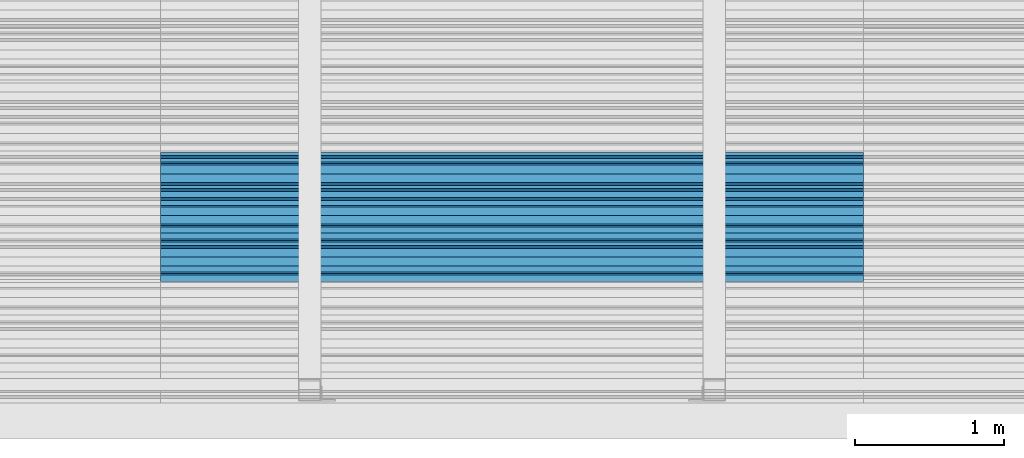
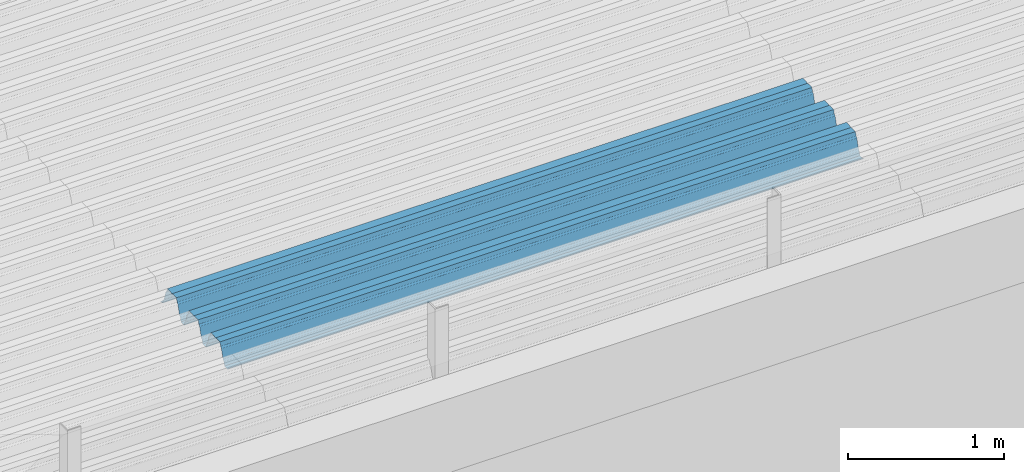
# One storey, part 30 of 153: 1 beam, 1 element without a shape of its own.
"""IFC2X3 building model written with IfcOpenShell, lengths in millimetres."""

import ifcopenshell
import ifcopenshell.guid

model = None  # the IFC model being written
_history = None  # IfcOwnerHistory: only IFC2X3 demands one
_inside = {}  # id of a spatial element -> (the spatial element, [elements in it])
_under = {}  # id of a project, library or spatial element -> (it, [spatial elements below it])
_declared = {}  # id of a project -> (the project, [libraries it declares])
_typed = {}  # id of a type object -> (the type object, [elements of that type])
_made_of = {}  # id of a material, layer set ... -> (it, [elements and type objects made of it])


def new_model(schema):
    """Start an empty IFC model of exactly this schema.

    Asked for "IFC4X3", IfcOpenShell would pick the latest addendum, in which some entities
    have other attributes; the version numbers below select the first issue.
    IFC2X3 requires an IfcOwnerHistory on every rooted entity: one is made here for all.
    """
    global model, _history
    if schema == "IFC4X3":
        model = ifcopenshell.file(schema_version=(4, 3, 0, 0))
    else:
        model = ifcopenshell.file(schema=schema)
    _inside.clear()
    _under.clear()
    _declared.clear()
    _typed.clear()
    _made_of.clear()
    _history = None
    if model.schema == "IFC2X3":
        org = make("IfcOrganization", Name="unknown")
        user = make(
            "IfcPersonAndOrganization",
            ThePerson=make("IfcPerson", FamilyName="unknown"),
            TheOrganization=org,
        )
        app = make(
            "IfcApplication",
            ApplicationDeveloper=org,
            Version="unknown",
            ApplicationFullName="unknown",
            ApplicationIdentifier="unknown",
        )
        _history = make(
            "IfcOwnerHistory",
            OwningUser=user,
            OwningApplication=app,
            ChangeAction="ADDED",
            CreationDate=0,
        )
    return model


def make(cls, **values):
    """One entity of the class cls with the attributes given. An attribute that is None is left unset."""
    return model.create_entity(
        cls, **{name: value for name, value in values.items() if value is not None}
    )


def rooted(cls, **values):
    """An entity with a GlobalId (a new one), such as an element, a storey or a relation."""
    return make(cls, GlobalId=ifcopenshell.guid.new(), OwnerHistory=_history, **values)


def si_unit(unit_type, name, prefix=None):
    """IfcSIUnit, for example si_unit("LENGTHUNIT", "METRE", prefix="MILLI")."""
    return make("IfcSIUnit", UnitType=unit_type, Prefix=prefix, Name=name)


def assignment(units):
    """IfcUnitAssignment: the units of a project."""
    return None if units is None else make("IfcUnitAssignment", Units=units)


def point(xyz):
    """IfcCartesianPoint."""
    return None if xyz is None else make("IfcCartesianPoint", Coordinates=xyz)


def direction(xyz):
    """IfcDirection."""
    return None if xyz is None else make("IfcDirection", DirectionRatios=xyz)


def frame(location, z_axis=None, x_axis=None):
    """IfcAxis2Placement3D, a coordinate frame: its origin and axes. An axis left out is left unset."""
    return make(
        "IfcAxis2Placement3D",
        Location=point(location),
        Axis=direction(z_axis),
        RefDirection=direction(x_axis),
    )


def origin_with_axes():
    """The frame at (0, 0, 0) with the z axis (0, 0, 1) and the x axis (1, 0, 0) written out."""
    return frame((0.0, 0.0, 0.0), z_axis=(0.0, 0.0, 1.0), x_axis=(1.0, 0.0, 0.0))


def place(relative_to, where):
    """IfcLocalPlacement: puts the frame where relative to a parent placement (None: the world)."""
    return make(
        "IfcLocalPlacement", PlacementRelTo=relative_to, RelativePlacement=where
    )


def context(
    kind, dimensions, precision=None, world=None, true_north=None, identifier=None
):
    """IfcGeometricRepresentationContext, for example the 3D "Model" context."""
    return make(
        "IfcGeometricRepresentationContext",
        ContextIdentifier=identifier,
        ContextType=kind,
        CoordinateSpaceDimension=dimensions,
        Precision=precision,
        WorldCoordinateSystem=world,
        TrueNorth=true_north,
    )


def subcontext(parent, identifier, kind, view, scale=None):
    """IfcGeometricRepresentationSubContext, for example "Body" below "Model"."""
    return make(
        "IfcGeometricRepresentationSubContext",
        ContextIdentifier=identifier,
        ContextType=kind,
        ParentContext=parent,
        TargetScale=scale,
        TargetView=view,
    )


def project(units=None, contexts=None):
    """IfcProject with its units and contexts."""
    return rooted(
        "IfcProject",
        Name="project",
        RepresentationContexts=contexts,
        UnitsInContext=assignment(units),
    )


def spatial(cls, under=None, at=None, **own):
    """A site, building, storey or space (cls), placed at a placement, below another one or the project."""
    s = rooted(cls, ObjectPlacement=at, **own)
    if under is not None:
        _under.setdefault(under.id(), (under, []))[1].append(s)
    return s


def faces_of(points, faces, orient=None, outer=None):
    """IfcFace entities. A face is a list of loops; a loop is a list of indices into points, from 0.

    orient and outer hold one flag for each loop. By default every Orientation is true, the
    first loop of a face is its IfcFaceOuterBound and the others are IfcFaceBound.
    """
    made = []
    for i, loops in enumerate(faces):
        bounds = []
        for j, loop in enumerate(loops):
            is_outer = j == 0 if outer is None else outer[i][j]
            bounds.append(
                make(
                    "IfcFaceOuterBound" if is_outer else "IfcFaceBound",
                    Bound=make("IfcPolyLoop", Polygon=[points[k] for k in loop]),
                    Orientation=True if orient is None else orient[i][j],
                )
            )
        made.append(make("IfcFace", Bounds=bounds))
    return made


def faceted_brep(points, faces, orient=None, outer=None, voids=None):
    """IfcFacetedBrep: a solid bounded by flat faces; with voids (closed shells), ...WithVoids."""
    shared = [point(p) for p in points]
    hull = make("IfcClosedShell", CfsFaces=faces_of(shared, faces, orient, outer))
    if voids is None:
        return make("IfcFacetedBrep", Outer=hull)
    return make(
        "IfcFacetedBrepWithVoids",
        Outer=hull,
        Voids=[
            make(cls, CfsFaces=faces_of(shared, fs, o, b)) for cls, fs, o, b in voids
        ],
    )


def shape(context_of_items, identifier, shape_type, items):
    """IfcShapeRepresentation: the items that make up one representation, for example the "Body"."""
    return make(
        "IfcShapeRepresentation",
        ContextOfItems=context_of_items,
        RepresentationIdentifier=identifier,
        RepresentationType=shape_type,
        Items=items,
    )


def material(Name=None, Category=None):
    """IfcMaterial."""
    return make("IfcMaterial", Name=Name, Category=Category)


def made_of(thing, what):
    """Note that an element or type object is made of a material, layer set ...; save() writes the relation."""
    if what is not None:
        _made_of.setdefault(what.id(), (what, []))[1].append(thing)
    return thing


def type_object(cls, material=None, **own):
    """A type object (cls), such as IfcWallType, which elements share."""
    return made_of(rooted(cls, **own), material)


def element(
    cls,
    number,
    at=None,
    inside=None,
    cuts=None,
    type_object=None,
    material=None,
    context=None,
    identifier="Body",
    shape_type=None,
    held_by="IfcProductDefinitionShape",
    body=None,
    shapes=None,
    **own,
):
    """One element of the class cls, such as IfcWall. Its Tag is "e" and its number.

    at: its placement. inside: the storey or other place that contains it. cuts: it is an
    opening in that element (IfcRelVoidsElement). A single representation is given by context,
    identifier, shape_type and body (its items); several are given by shapes. held_by: the class
    of the entity that holds the representations. save() writes the other relations.
    """
    e = rooted(cls, Tag="e%d" % number, ObjectPlacement=at, **own)
    if body is not None:
        shapes = [shape(context, identifier, shape_type, body)]
    if shapes is not None:
        e.Representation = make(held_by, Representations=shapes)
    if inside is not None:
        _inside.setdefault(inside.id(), (inside, []))[1].append(e)
    if cuts is not None:
        rooted(
            "IfcRelVoidsElement", RelatingBuildingElement=cuts, RelatedOpeningElement=e
        )
    if type_object is not None:
        _typed.setdefault(type_object.id(), (type_object, []))[1].append(e)
    return made_of(e, material)


def aggregate(whole, parts):
    """IfcRelAggregates: a whole, such as a stair, and the parts it consists of."""
    return rooted("IfcRelAggregates", RelatingObject=whole, RelatedObjects=parts)


def save(model, path):
    """Write the relations noted so far, then the file.

    IfcRelAggregates (storeys below a building ...), IfcRelContainedInSpatialStructure (elements
    in a storey), IfcRelDefinesByType, IfcRelAssociatesMaterial and IfcRelDeclares: one each for
    every whole, place, type object, material and project.
    """
    for whole, parts in _under.values():
        aggregate(whole, parts)
    for where, things in _inside.values():
        rooted(
            "IfcRelContainedInSpatialStructure",
            RelatedElements=things,
            RelatingStructure=where,
        )
    for kind, things in _typed.values():
        rooted("IfcRelDefinesByType", RelatedObjects=things, RelatingType=kind)
    for what, things in _made_of.values():
        rooted("IfcRelAssociatesMaterial", RelatedObjects=things, RelatingMaterial=what)
    for by, libraries in _declared.values():
        rooted("IfcRelDeclares", RelatingContext=by, RelatedDefinitions=libraries)
    model.write(path)


model = new_model("IFC2X3")

# Units and contexts
model_context = context("Model", 3, precision=1e-05, world=origin_with_axes())
body_context = subcontext(model_context, "Body", "Model", "MODEL_VIEW")
ifc_project = project(units=[si_unit("LENGTHUNIT", "METRE", prefix="MILLI"), si_unit("AREAUNIT", "SQUARE_METRE"), si_unit("VOLUMEUNIT", "CUBIC_METRE"), si_unit("MASSUNIT", "GRAM", prefix="KILO"), si_unit("TIMEUNIT", "SECOND"), si_unit("PLANEANGLEUNIT", "RADIAN"), si_unit("SOLIDANGLEUNIT", "STERADIAN"), si_unit("THERMODYNAMICTEMPERATUREUNIT", "DEGREE_CELSIUS"), si_unit("LUMINOUSINTENSITYUNIT", "LUMEN")], contexts=[model_context])

# Site, building, storey
site_placement = place(None, origin_with_axes())
site = spatial("IfcSite", under=ifc_project, at=site_placement, CompositionType="ELEMENT")
building_placement = place(site_placement, origin_with_axes())
building = spatial("IfcBuilding", under=site, at=building_placement, CompositionType="ELEMENT")
storey_placement = place(building_placement, origin_with_axes())
storey = spatial("IfcBuildingStorey", under=building, at=storey_placement, Name="8", CompositionType="ELEMENT", Elevation=0.0)

# Assembly, beam
assembly_placement = place(storey_placement, origin_with_axes())
assembly = element("IfcElementAssembly", 1, at=assembly_placement, inside=storey, Name="Steel Assembly", AssemblyPlace="NOTDEFINED", PredefinedType="RIGID_FRAME")
ifc_material = material(Name="STEEL/S355J2")
beam_type = type_object("IfcBeamType", Name="W", PredefinedType="NOTDEFINED")
beam_placement = place(assembly_placement, frame((17251.9999999917, 16215.1442180518, 105760.274680724), z_axis=(0.0, -0.0124990270013869, 0.999921884110963), x_axis=(-1.0, 3.00000001838171e-08, 0.0)))
beam = element("IfcBeam", 2, at=beam_placement, type_object=beam_type, material=ifc_material, ObjectType="W", context=body_context, shape_type="Brep", body=[
    faceted_brep([(0.0, -412.839996337891, -77.0100021362159), (0.0, -409.160003662109, -77.0100021362014), (4717.0, -409.160003662109, -77.0100021362159), (4717.0, -412.839996337891, -77.0100021362159), (0.0, -408.070007324222, -73.4800033569045), (4717.0, -408.070007324222, -73.480003356919), (0.0, -400.339996337894, -48.0600013732619), (4717.0, -400.339996337894, -48.0600013732765), (0.0, -399.459991455082, -46.5600013732619), (4717.0, -399.459991455078, -46.5600013732765), (0.0, -390.329986572269, -36.5499992370314), (4717.0, -390.329986572266, -36.549999237046), (0.0, -389.19000244141, -34.6300010680861), (4717.0, -389.190002441403, -34.6300010681007), (0.0, -367.820007324222, 35.3400001526024), (4717.0, -367.820007324219, 35.3400001525879), (0.0, -366.989990234379, 36.8499984741502), (4717.0, -366.989990234375, 36.8499984741356), (0.0, -357.809997558597, 46.8600006103807), (4717.0, -357.809997558594, 46.8600006103661), (0.0, -356.720001220707, 48.7700004577782), (4717.0, -356.720001220703, 48.7700004577782), (0.0, -349.309997558594, 73.1500015258935), (4717.0, -349.309997558594, 73.1500015258935), (0.0, -347.850006103516, 75.2300033569481), (4717.0, -347.850006103516, 75.2300033569481), (0.0, -345.470001220707, 76.010002136245), (4717.0, -345.470001220703, 76.0100021362305), (0.0, -305.480010986332, 76.010002136245), (4717.0, -305.480010986324, 76.0100021362305), (0.0, -304.279998779301, 75.8000030517578), (4717.0, -304.279998779301, 75.8000030517724), (0.0, -291.679992675785, 71.6999969482567), (4717.0, -291.679992675785, 71.6999969482567), (0.0, -290.179992675789, 71.2300033569481), (4717.0, -290.179992675781, 71.2300033569481), (0.0, -288.720001220707, 71.6999969482567), (4717.0, -288.720001220703, 71.6999969482422), (0.0, -276.119995117191, 75.8000030517869), (4717.0, -276.119995117188, 75.8000030517724), (0.0, -274.929992675785, 76.010002136245), (4717.0, -274.929992675785, 76.010002136245), (0.0, -234.94000244141, 76.010002136245), (4717.0, -234.94000244141, 76.010002136245), (0.0, -232.550003051758, 75.2300033569627), (4717.0, -232.550003051758, 75.2300033569481), (0.0, -231.100006103519, 73.1500015258935), (4717.0, -231.100006103516, 73.1500015258789), (0.0, -223.679992675785, 48.7700004577782), (4717.0, -223.679992675781, 48.7700004577782), (0.0, -222.589996337894, 46.8600006103661), (4717.0, -222.589996337891, 46.8600006103516), (0.0, -213.410003662113, 36.8499984741502), (4717.0, -213.410003662109, 36.8499984741356), (0.0, -212.529998779301, 35.3400001526024), (4717.0, -212.529998779297, 35.3400001526024), (0.0, -191.160003662109, -34.6300010681007), (4717.0, -191.160003662109, -34.6300010681007), (0.0, -190.070007324222, -36.5499992370605), (4717.0, -190.070007324215, -36.549999237046), (0.0, -180.940002441406, -46.560001373291), (4717.0, -180.940002441406, -46.5600013732765), (0.0, -180.059997558597, -48.0600013732619), (4717.0, -180.059997558594, -48.0600013732765), (0.0, -172.330001831055, -73.480003356919), (4717.0, -172.330001831055, -73.480003356919), (0.0, -171.240005493168, -77.0100021362159), (4717.0, -171.240005493164, -77.0100021362159), (0.0, -129.330001831062, -77.0100021362014), (4717.0, -129.330001831055, -77.0100021362159), (0.0, -128.300003051761, -73.480003356919), (4717.0, -128.300003051758, -73.4800033569336), (0.0, -120.51999664307, -48.0600013732765), (4717.0, -120.519996643063, -48.0600013732765), (0.0, -119.629997253418, -46.5600013732765), (4717.0, -119.629997253418, -46.5600013732765), (0.0, -110.500000000004, -36.5499992370314), (4717.0, -110.5, -36.549999237046), (0.0, -109.419998168949, -34.6300010680861), (4717.0, -109.419998168945, -34.6300010681007), (0.0, -88.0500030517615, 35.3400001526024), (4717.0, -88.0500030517578, 35.3400001526024), (0.0, -87.160003662113, 36.8499984741356), (4717.0, -87.160003662113, 36.8499984741356), (0.0, -78.0400009155273, 46.8600006103807), (4717.0, -78.0400009155273, 46.8600006103661), (0.0, -76.8899993896557, 48.7700004577782), (4717.0, -76.8899993896521, 48.7700004577782), (0.0, -69.4800033569336, 73.1500015258935), (4717.0, -69.4800033569336, 73.1500015258935), (0.0, -68.0299987793042, 75.2300033569336), (4717.0, -68.0299987792969, 75.2300033569481), (0.0, -65.6399993896521, 76.010002136245), (4717.0, -65.6399993896484, 76.010002136245), (0.0, -25.6499996185375, 76.0100021362596), (4717.0, -25.6499996185303, 76.010002136245), (0.0, -24.5100002288891, 75.8000030517724), (4717.0, -24.5100002288818, 75.8000030517724), (0.0, -11.8500003814697, 71.6999969482567), (4717.0, -11.8500003814661, 71.6999969482567), (0.0, -10.3999996185339, 71.2300033569481), (4717.0, -10.3999996185303, 71.2300033569336), (0.0, -8.89999961853391, 71.6999969482567), (4717.0, -8.89999961853391, 71.6999969482567), (0.0, 3.71000003814333, 75.8000030517724), (4717.0, 3.71000003814697, 75.8000030517869), (0.0, 4.90000009536379, 76.0100021362596), (4717.0, 4.90000009536379, 76.010002136245), (0.0, 44.8899993896484, 76.010002136245), (4717.0, 44.8899993896484, 76.010002136245), (0.0, 47.2799987792932, 75.2300033569481), (4717.0, 47.2799987792969, 75.2300033569481), (0.0, 48.6800003051721, 73.1500015258935), (4717.0, 48.6800003051758, 73.1500015258789), (0.0, 56.1500015258753, 48.7700004577782), (4717.0, 56.1500015258789, 48.7700004577782), (0.0, 57.2400016784632, 46.8600006103807), (4717.0, 57.2400016784632, 46.8600006103661), (0.0, 66.3700027465784, 36.8499984741211), (4717.0, 66.3700027465857, 36.8499984741356), (0.0, 67.2499999999964, 35.3400001526024), (4717.0, 67.2500000000036, 35.3400001526024), (0.0, 88.6200027465748, -34.6300010681007), (4717.0, 88.620002746582, -34.6300010681152), (0.0, 89.709999084469, -36.549999237046), (4717.0, 89.7099990844727, -36.5499992370605), (0.0, 98.8899993896412, -46.5600013732765), (4717.0, 98.8899993896484, -46.5600013732765), (0.0, 99.7699966430628, -48.0600013732765), (4717.0, 99.7699966430664, -48.060001373291), (0.0, 107.499999999996, -73.4800033569336), (4717.0, 107.5, -73.480003356919), (0.0, 108.589996337887, -77.0100021362014), (4717.0, 108.589996337894, -77.0100021362159), (0.0, 112.269996643063, -77.0100021362159), (4717.0, 112.269996643066, -77.0100021362159), (0.0, 146.759994506836, -77.0100021362159), (4717.0, 146.759994506836, -77.0100021362159), (0.0, 150.440002441403, -77.0100021362159), (4717.0, 150.440002441403, -77.0100021362305), (0.0, 151.529998779297, -73.480003356919), (4717.0, 151.529998779297, -73.4800033569336), (0.0, 159.30999755859, -48.0600013732765), (4717.0, 159.309997558594, -48.0600013732765), (0.0, 160.190002441406, -46.5600013732619), (4717.0, 160.190002441406, -46.5600013732765), (0.0, 169.320007324215, -36.549999237046), (4717.0, 169.320007324222, -36.5499992370605), (0.0, 170.410003662106, -34.6300010680861), (4717.0, 170.410003662109, -34.6300010681007), (0.0, 191.779998779293, 35.3400001526024), (4717.0, 191.779998779293, 35.3400001526024), (0.0, 192.660003662109, 36.8499984741502), (4717.0, 192.660003662109, 36.8499984741356), (0.0, 201.789993286129, 46.8600006103661), (4717.0, 201.789993286133, 46.8600006103661), (0.0, 202.880004882809, 48.7700004577637), (4717.0, 202.880004882813, 48.7700004577782), (0.0, 210.350006103512, 73.150001525908), (4717.0, 210.350006103516, 73.1500015258935), (0.0, 211.800003051754, 75.2300033569481), (4717.0, 211.800003051758, 75.2300033569336), (0.0, 214.190002441406, 76.010002136245), (4717.0, 214.19000244141, 76.010002136245), (0.0, 254.179992675778, 76.010002136245), (4717.0, 254.179992675778, 76.010002136245), (0.0, 255.320007324215, 75.8000030517869), (4717.0, 255.320007324222, 75.8000030517724), (0.0, 267.980010986324, 71.6999969482713), (4717.0, 267.980010986328, 71.6999969482567), (0.0, 269.429992675778, 71.2300033569481), (4717.0, 269.429992675781, 71.2300033569481), (0.0, 270.880004882809, 71.6999969482567), (4717.0, 270.880004882813, 71.6999969482567), (0.0, 283.540008544918, 75.8000030517869), (4717.0, 283.540008544918, 75.8000030517724), (0.0, 284.679992675778, 76.010002136245), (4717.0, 284.679992675778, 76.010002136245), (0.0, 324.670013427731, 76.010002136245), (4717.0, 324.670013427738, 76.010002136245), (0.0, 327.049987792969, 75.2300033569627), (4717.0, 327.049987792969, 75.2300033569481), (0.0, 328.510009765625, 73.1500015258789), (4717.0, 328.510009765625, 73.1500015258935), (0.0, 335.980010986324, 48.7700004577782), (4717.0, 335.980010986328, 48.7700004577782), (0.0, 337.05999755859, 46.8600006103661), (4717.0, 337.059997558594, 46.8600006103516), (0.0, 346.190002441399, 36.8499984741356), (4717.0, 346.190002441406, 36.8499984741211), (0.0, 347.079986572266, 35.3400001526024), (4717.0, 347.079986572266, 35.3400001526024), (0.0, 368.450012207028, -34.6300010680861), (4717.0, 368.450012207035, -34.6300010681007), (0.0, 369.529998779293, -36.5499992370314), (4717.0, 369.529998779297, -36.549999237046), (0.0, 378.660003662106, -46.5600013732619), (4717.0, 378.660003662106, -46.5600013732765), (0.0, 379.540008544918, -48.0600013732619), (4717.0, 379.540008544922, -48.0600013732765), (0.0, 387.329986572262, -73.480003356919), (4717.0, 387.329986572266, -73.4800033569045), (0.0, 388.410003662109, -77.0100021362159), (4717.0, 388.410003662109, -77.0100021362159), (0.0, 392.100006103512, -77.0100021362159), (4717.0, 392.100006103519, -77.0100021362159), (0.0, 426.589996337887, -77.0100021362159), (4717.0, 426.589996337891, -77.0100021362159), (0.0, 430.269989013668, -77.0100021362159), (4717.0, 430.269989013672, -77.0100021362305), (0.0, 431.359985351559, -73.4800033569045), (4717.0, 431.359985351563, -73.480003356919), (0.0, 433.179992675778, -67.5699996948097), (4717.0, 433.179992675781, -67.5699996948097), (0.0, 432.220001220699, -67.2699966430373), (4717.0, 432.220001220703, -67.2699966430519), (0.0, 430.410003662106, -73.1800003051612), (4717.0, 430.410003662106, -73.1800003051758), (0.0, 429.529998779293, -76.0100021362159), (4717.0, 429.529998779293, -76.0100021362159), (0.0, 426.589996337891, -76.0100021362159), (4717.0, 426.589996337891, -76.0100021362159), (0.0, 392.100006103512, -76.0100021362159), (4717.0, 392.100006103516, -76.0100021362159), (0.0, 389.149993896481, -76.0100021362014), (4717.0, 389.149993896484, -76.0100021362159), (0.0, 388.279998779293, -73.1800003051467), (4717.0, 388.279998779301, -73.1800003051612), (0.0, 380.470001220699, -47.659999847383), (4717.0, 380.470001220703, -47.6599998473976), (0.0, 379.470001220699, -45.9599990844436), (4717.0, 379.470001220703, -45.9599990844581), (0.0, 370.350006103512, -35.9599990844581), (4717.0, 370.350006103519, -35.9599990844581), (0.0, 369.369995117184, -34.2299995422218), (4717.0, 369.369995117184, -34.2299995422218), (0.0, 347.999999999996, 35.7500000000146), (4717.0, 348.0, 35.7500000000146), (0.0, 346.999999999996, 37.4399986267235), (4717.0, 347.000000000004, 37.4399986267235), (0.0, 337.880004882809, 47.450000762954), (4717.0, 337.880004882809, 47.4500007629395), (0.0, 336.899993896481, 49.1699981689453), (4717.0, 336.899993896484, 49.1699981689599), (0.0, 329.420013427731, 73.5999984741356), (4717.0, 329.420013427734, 73.5999984741356), (0.0, 327.679992675781, 76.0699996948533), (4717.0, 327.679992675781, 76.0699996948388), (0.0, 324.829986572262, 77.010002136245), (4717.0, 324.829986572266, 77.0100021362305), (0.0, 284.589996337887, 77.010002136245), (4717.0, 284.589996337891, 77.010002136245), (0.0, 283.290008544922, 76.769996643081), (4717.0, 283.290008544922, 76.769996643081), (0.0, 270.570007324215, 72.6500015258935), (4717.0, 270.570007324219, 72.6500015258935), (0.0, 269.429992675781, 72.2799987793114), (4717.0, 269.429992675781, 72.2799987793114), (0.0, 268.279998779293, 72.650001525908), (4717.0, 268.279998779297, 72.6500015258935), (0.0, 255.570007324219, 76.769996643081), (4717.0, 255.570007324219, 76.769996643081), (0.0, 254.270004272461, 77.0100021362596), (4717.0, 254.270004272461, 77.010002136245), (0.0, 214.029998779293, 77.0100021362596), (4717.0, 214.029998779297, 77.010002136245), (0.0, 211.179992675781, 76.0699996948388), (4717.0, 211.179992675781, 76.0699996948533), (0.0, 209.440002441403, 73.5999984741356), (4717.0, 209.44000244141, 73.5999984741211), (0.0, 201.960006713864, 49.1699981689599), (4717.0, 201.960006713867, 49.1699981689453), (0.0, 200.979995727532, 47.450000762954), (4717.0, 200.979995727539, 47.4500007629395), (0.0, 191.850006103508, 37.4399986267235), (4717.0, 191.850006103516, 37.439998626709), (0.0, 190.860000610352, 35.7500000000146), (4717.0, 190.860000610352, 35.75), (0.0, 169.49000549316, -34.2299995422218), (4717.0, 169.49000549316, -34.2299995422363), (0.0, 168.509994506832, -35.9599990844581), (4717.0, 168.509994506836, -35.9599990844581), (0.0, 159.380004882805, -45.9599990844436), (4717.0, 159.380004882813, -45.9599990844581), (0.0, 158.389999389645, -47.6599998473976), (4717.0, 158.389999389645, -47.6599998474121), (0.0, 150.580001831051, -73.1800003051612), (4717.0, 150.580001831058, -73.1800003051758), (0.0, 149.710006713864, -76.0100021362159), (4717.0, 149.710006713867, -76.0100021362159), (0.0, 146.759994506836, -76.0100021362159), (4717.0, 146.759994506836, -76.0100021362159), (0.0, 112.269996643063, -76.0100021362159), (4717.0, 112.269996643063, -76.0100021362159), (0.0, 109.319999694821, -76.0100021362159), (4717.0, 109.319999694821, -76.0100021362159), (0.0, 108.449996948239, -73.1900024413917), (4717.0, 108.449996948242, -73.1900024414063), (0.0, 100.690002441406, -47.659999847383), (4717.0, 100.69000244141, -47.6599998473976), (0.0, 99.6999969482386, -45.9599990844581), (4717.0, 99.6999969482422, -45.9599990844581), (0.0, 90.5199966430664, -35.9599990844581), (4717.0, 90.5199966430664, -35.9599990844727), (0.0, 89.5400009155273, -34.2299995422218), (4717.0, 89.5400009155273, -34.2299995422218), (0.0, 68.1699981689417, 35.7500000000146), (4717.0, 68.1699981689453, 35.7500000000146), (0.0, 67.1699981689417, 37.4399986267235), (4717.0, 67.1699981689453, 37.4399986267235), (0.0, 58.0499992370569, 47.4500007629686), (4717.0, 58.0499992370605, 47.450000762954), (0.0, 57.0699996948206, 49.1699981689599), (4717.0, 57.0699996948279, 49.1699981689453), (0.0, 49.5900001525843, 73.5899963379052), (4717.0, 49.5900001525879, 73.5899963378906), (0.0, 47.9099998474085, 76.0699996948388), (4717.0, 47.9099998474121, 76.0699996948242), (0.0, 45.0499992370569, 77.010002136245), (4717.0, 45.0499992370605, 77.010002136245), (0.0, 4.82000017165774, 77.010002136245), (4717.0, 4.82000017166138, 77.010002136245), (0.0, 3.47000002860659, 76.7699966430955), (4717.0, 3.47000002860659, 76.769996643081), (0.0, -9.19999980926514, 72.6500015258935), (4717.0, -9.19999980926514, 72.6500015258789), (0.0, -10.3900003433264, 72.2799987792969), (4717.0, -10.3900003433228, 72.2799987793114), (0.0, -11.5399999618567, 72.6500015258935), (4717.0, -11.5399999618494, 72.6500015258935), (0.0, -24.2600002288855, 76.769996643081), (4717.0, -24.2600002288818, 76.769996643081), (0.0, -25.559999465946, 77.0100021362596), (4717.0, -25.5599994659424, 77.010002136245), (0.0, -65.8000030517615, 77.0100021362596), (4717.0, -65.8000030517578, 77.010002136245), (0.0, -68.6500015258862, 76.0699996948533), (4717.0, -68.6500015258825, 76.0699996948388), (0.0, -70.3899993896521, 73.5999984741356), (4717.0, -70.3899993896484, 73.5999984741211), (0.0, -77.8199996948242, 49.1800003051903), (4717.0, -77.8199996948242, 49.1800003051903), (0.0, -78.8399963378943, 47.450000762954), (4717.0, -78.8399963378906, 47.4500007629395), (0.0, -87.9700012207031, 37.4399986267235), (4717.0, -87.9700012207031, 37.4399986267235), (0.0, -88.9700012207068, 35.7500000000146), (4717.0, -88.9700012207031, 35.75), (0.0, -110.339996337894, -34.2299995422218), (4717.0, -110.339996337887, -34.2299995422218), (0.0, -111.319999694828, -35.9599990844581), (4717.0, -111.319999694824, -35.9599990844581), (0.0, -120.440002441406, -45.9599990844436), (4717.0, -120.440002441406, -45.9599990844581), (0.0, -121.44000244141, -47.6599998473976), (4717.0, -121.440002441403, -47.6599998473976), (0.0, -129.250000000004, -73.1900024413771), (4717.0, -129.25, -73.1900024413917), (0.0, -130.080001831062, -76.0100021362159), (4717.0, -130.080001831055, -76.0100021362159), (0.0, -170.5, -76.0100021362014), (4717.0, -170.5, -76.0100021362159), (0.0, -171.380004882816, -73.1900024413917), (4717.0, -171.380004882813, -73.1900024414063), (0.0, -179.139999389652, -47.6599998473976), (4717.0, -179.139999389648, -47.6599998473976), (0.0, -180.130004882816, -45.9599990844581), (4717.0, -180.130004882813, -45.9599990844581), (0.0, -189.259994506836, -35.9599990844581), (4717.0, -189.259994506832, -35.9599990844581), (0.0, -190.240005493168, -34.2299995422218), (4717.0, -190.240005493164, -34.2299995422218), (0.0, -211.610000610355, 35.7500000000146), (4717.0, -211.610000610352, 35.7500000000146), (0.0, -212.600006103519, 37.4399986267381), (4717.0, -212.600006103519, 37.4399986267235), (0.0, -221.779998779301, 47.450000762954), (4717.0, -221.779998779293, 47.4500007629395), (0.0, -222.75999450684, 49.1699981689599), (4717.0, -222.759994506836, 49.1699981689599), (0.0, -230.190002441406, 73.5999984741356), (4717.0, -230.190002441406, 73.5999984741211), (0.0, -231.919998168945, 76.0699996948388), (4717.0, -231.919998168945, 76.0699996948388), (0.0, -234.779998779301, 77.010002136245), (4717.0, -234.779998779293, 77.010002136245), (0.0, -275.010009765629, 77.010002136245), (4717.0, -275.010009765625, 77.0100021362305), (0.0, -276.359985351563, 76.769996643081), (4717.0, -276.359985351563, 76.7699966430664), (0.0, -289.029998779297, 72.6500015258789), (4717.0, -289.029998779297, 72.6500015258935), (0.0, -290.179992675785, 72.2799987793114), (4717.0, -290.179992675785, 72.2799987793114), (0.0, -291.380004882816, 72.650001525908), (4717.0, -291.380004882813, 72.6500015258935), (0.0, -304.040008544926, 76.769996643081), (4717.0, -304.040008544918, 76.769996643081), (0.0, -305.390014648441, 77.010002136245), (4717.0, -305.390014648438, 77.010002136245), (0.0, -345.63000488282, 77.0100021362596), (4717.0, -345.630004882813, 77.010002136245), (0.0, -348.480010986332, 76.0699996948388), (4717.0, -348.480010986324, 76.0699996948388), (0.0, -350.220001220707, 73.5999984741356), (4717.0, -350.220001220703, 73.5999984741211), (0.0, -357.649993896492, 49.1699981689599), (4717.0, -357.649993896484, 49.1699981689744), (0.0, -358.63000488282, 47.450000762954), (4717.0, -358.630004882813, 47.450000762954), (0.0, -367.809997558594, 37.4300003051903), (4717.0, -367.809997558594, 37.4300003051903), (0.0, -368.750000000004, 35.7299995422654), (4717.0, -368.75, 35.7299995422509), (0.0, -390.109985351566, -34.2200012207031), (4717.0, -390.109985351563, -34.2200012206886), (0.0, -391.140014648441, -35.9500007629249), (4717.0, -391.140014648438, -35.9500007629103), (0.0, -400.269989013676, -45.9599990844436), (4717.0, -400.269989013672, -45.9599990844581), (0.0, -401.269989013672, -47.6599998473976), (4717.0, -401.269989013672, -47.6599998473976), (0.0, -409.029998779297, -73.1900024413917), (4717.0, -409.029998779297, -73.1900024413917), (0.0, -409.899993896488, -76.0100021362159), (4717.0, -409.899993896481, -76.0100021362305), (0.0, -412.839996337891, -76.0100021362159), (4717.0, -412.839996337891, -76.0100021362305), (0.0, -433.179992675785, -76.0100021362159), (4717.0, -433.179992675781, -76.0100021362159), (0.0, -433.179992675785, -77.0100021362159), (4717.0, -433.179992675785, -77.0100021362305)], [[[0, 1, 2, 3]], [[1, 4, 5, 2]], [[4, 6, 7, 5]], [[6, 8, 9, 7]], [[8, 10, 11, 9]], [[10, 12, 13, 11]], [[12, 14, 15, 13]], [[14, 16, 17, 15]], [[16, 18, 19, 17]], [[18, 20, 21, 19]], [[20, 22, 23, 21]], [[22, 24, 25, 23]], [[24, 26, 27, 25]], [[26, 28, 29, 27]], [[28, 30, 31, 29]], [[30, 32, 33, 31]], [[32, 34, 35, 33]], [[34, 36, 37, 35]], [[36, 38, 39, 37]], [[38, 40, 41, 39]], [[40, 42, 43, 41]], [[42, 44, 45, 43]], [[44, 46, 47, 45]], [[46, 48, 49, 47]], [[48, 50, 51, 49]], [[50, 52, 53, 51]], [[52, 54, 55, 53]], [[54, 56, 57, 55]], [[56, 58, 59, 57]], [[58, 60, 61, 59]], [[60, 62, 63, 61]], [[62, 64, 65, 63]], [[64, 66, 67, 65]], [[66, 68, 69, 67]], [[68, 70, 71, 69]], [[70, 72, 73, 71]], [[72, 74, 75, 73]], [[74, 76, 77, 75]], [[76, 78, 79, 77]], [[78, 80, 81, 79]], [[80, 82, 83, 81]], [[82, 84, 85, 83]], [[84, 86, 87, 85]], [[86, 88, 89, 87]], [[88, 90, 91, 89]], [[90, 92, 93, 91]], [[92, 94, 95, 93]], [[94, 96, 97, 95]], [[96, 98, 99, 97]], [[98, 100, 101, 99]], [[100, 102, 103, 101]], [[102, 104, 105, 103]], [[104, 106, 107, 105]], [[106, 108, 109, 107]], [[108, 110, 111, 109]], [[110, 112, 113, 111]], [[112, 114, 115, 113]], [[114, 116, 117, 115]], [[116, 118, 119, 117]], [[118, 120, 121, 119]], [[120, 122, 123, 121]], [[122, 124, 125, 123]], [[124, 126, 127, 125]], [[126, 128, 129, 127]], [[128, 130, 131, 129]], [[130, 132, 133, 131]], [[132, 134, 135, 133]], [[134, 136, 137, 135]], [[136, 138, 139, 137]], [[138, 140, 141, 139]], [[140, 142, 143, 141]], [[142, 144, 145, 143]], [[144, 146, 147, 145]], [[146, 148, 149, 147]], [[148, 150, 151, 149]], [[150, 152, 153, 151]], [[152, 154, 155, 153]], [[154, 156, 157, 155]], [[156, 158, 159, 157]], [[158, 160, 161, 159]], [[160, 162, 163, 161]], [[162, 164, 165, 163]], [[164, 166, 167, 165]], [[166, 168, 169, 167]], [[168, 170, 171, 169]], [[170, 172, 173, 171]], [[172, 174, 175, 173]], [[174, 176, 177, 175]], [[176, 178, 179, 177]], [[178, 180, 181, 179]], [[180, 182, 183, 181]], [[182, 184, 185, 183]], [[184, 186, 187, 185]], [[186, 188, 189, 187]], [[188, 190, 191, 189]], [[190, 192, 193, 191]], [[192, 194, 195, 193]], [[194, 196, 197, 195]], [[196, 198, 199, 197]], [[198, 200, 201, 199]], [[200, 202, 203, 201]], [[202, 204, 205, 203]], [[204, 206, 207, 205]], [[206, 208, 209, 207]], [[208, 210, 211, 209]], [[210, 212, 213, 211]], [[212, 214, 215, 213]], [[214, 216, 217, 215]], [[216, 218, 219, 217]], [[218, 220, 221, 219]], [[220, 222, 223, 221]], [[222, 224, 225, 223]], [[224, 226, 227, 225]], [[226, 228, 229, 227]], [[228, 230, 231, 229]], [[230, 232, 233, 231]], [[232, 234, 235, 233]], [[234, 236, 237, 235]], [[236, 238, 239, 237]], [[238, 240, 241, 239]], [[240, 242, 243, 241]], [[242, 244, 245, 243]], [[244, 246, 247, 245]], [[246, 248, 249, 247]], [[248, 250, 251, 249]], [[250, 252, 253, 251]], [[252, 254, 255, 253]], [[254, 256, 257, 255]], [[256, 258, 259, 257]], [[258, 260, 261, 259]], [[260, 262, 263, 261]], [[262, 264, 265, 263]], [[264, 266, 267, 265]], [[266, 268, 269, 267]], [[268, 270, 271, 269]], [[270, 272, 273, 271]], [[272, 274, 275, 273]], [[274, 276, 277, 275]], [[276, 278, 279, 277]], [[278, 280, 281, 279]], [[280, 282, 283, 281]], [[282, 284, 285, 283]], [[284, 286, 287, 285]], [[286, 288, 289, 287]], [[288, 290, 291, 289]], [[290, 292, 293, 291]], [[292, 294, 295, 293]], [[294, 296, 297, 295]], [[296, 298, 299, 297]], [[298, 300, 301, 299]], [[300, 302, 303, 301]], [[302, 304, 305, 303]], [[304, 306, 307, 305]], [[306, 308, 309, 307]], [[308, 310, 311, 309]], [[310, 312, 313, 311]], [[312, 314, 315, 313]], [[314, 316, 317, 315]], [[316, 318, 319, 317]], [[318, 320, 321, 319]], [[320, 322, 323, 321]], [[322, 324, 325, 323]], [[324, 326, 327, 325]], [[326, 328, 329, 327]], [[328, 330, 331, 329]], [[330, 332, 333, 331]], [[332, 334, 335, 333]], [[334, 336, 337, 335]], [[336, 338, 339, 337]], [[338, 340, 341, 339]], [[340, 342, 343, 341]], [[342, 344, 345, 343]], [[344, 346, 347, 345]], [[346, 348, 349, 347]], [[348, 350, 351, 349]], [[350, 352, 353, 351]], [[352, 354, 355, 353]], [[354, 356, 357, 355]], [[356, 358, 359, 357]], [[358, 360, 361, 359]], [[360, 362, 363, 361]], [[362, 364, 365, 363]], [[364, 366, 367, 365]], [[366, 368, 369, 367]], [[368, 370, 371, 369]], [[370, 372, 373, 371]], [[372, 374, 375, 373]], [[374, 376, 377, 375]], [[376, 378, 379, 377]], [[378, 380, 381, 379]], [[380, 382, 383, 381]], [[382, 384, 385, 383]], [[384, 386, 387, 385]], [[386, 388, 389, 387]], [[388, 390, 391, 389]], [[390, 392, 393, 391]], [[392, 394, 395, 393]], [[394, 396, 397, 395]], [[396, 398, 399, 397]], [[398, 400, 401, 399]], [[400, 402, 403, 401]], [[402, 404, 405, 403]], [[404, 406, 407, 405]], [[406, 408, 409, 407]], [[408, 410, 411, 409]], [[410, 412, 413, 411]], [[412, 414, 415, 413]], [[414, 416, 417, 415]], [[416, 418, 419, 417]], [[418, 420, 421, 419]], [[420, 422, 423, 421]], [[422, 424, 425, 423]], [[424, 426, 427, 425]], [[426, 428, 429, 427]], [[428, 430, 431, 429]], [[430, 0, 3, 431]], [[5, 7, 9, 11, 13, 15, 17, 19, 21, 23, 25, 27, 29, 31, 33, 35, 37, 39, 41, 43, 45, 47, 49, 51, 53, 55, 57, 59, 61, 63, 65, 67, 69, 71, 73, 75, 77, 79, 81, 83, 85, 87, 89, 91, 93, 95, 97, 99, 101, 103, 105, 107, 109, 111, 113, 115, 117, 119, 121, 123, 125, 127, 129, 131, 133, 135, 137, 139, 141, 143, 145, 147, 149, 151, 153, 155, 157, 159, 161, 163, 165, 167, 169, 171, 173, 175, 177, 179, 181, 183, 185, 187, 189, 191, 193, 195, 197, 199, 201, 203, 205, 207, 209, 211, 213, 215, 217, 219, 221, 223, 225, 227, 229, 231, 233, 235, 237, 239, 241, 243, 245, 247, 249, 251, 253, 255, 257, 259, 261, 263, 265, 267, 269, 271, 273, 275, 277, 279, 281, 283, 285, 287, 289, 291, 293, 295, 297, 299, 301, 303, 305, 307, 309, 311, 313, 315, 317, 319, 321, 323, 325, 327, 329, 331, 333, 335, 337, 339, 341, 343, 345, 347, 349, 351, 353, 355, 357, 359, 361, 363, 365, 367, 369, 371, 373, 375, 377, 379, 381, 383, 385, 387, 389, 391, 393, 395, 397, 399, 401, 403, 405, 407, 409, 411, 413, 415, 417, 419, 421, 423, 425, 427, 429, 431, 3, 2]], [[430, 428, 426, 424, 422, 420, 418, 416, 414, 412, 410, 408, 406, 404, 402, 400, 398, 396, 394, 392, 390, 388, 386, 384, 382, 380, 378, 376, 374, 372, 370, 368, 366, 364, 362, 360, 358, 356, 354, 352, 350, 348, 346, 344, 342, 340, 338, 336, 334, 332, 330, 328, 326, 324, 322, 320, 318, 316, 314, 312, 310, 308, 306, 304, 302, 300, 298, 296, 294, 292, 290, 288, 286, 284, 282, 280, 278, 276, 274, 272, 270, 268, 266, 264, 262, 260, 258, 256, 254, 252, 250, 248, 246, 244, 242, 240, 238, 236, 234, 232, 230, 228, 226, 224, 222, 220, 218, 216, 214, 212, 210, 208, 206, 204, 202, 200, 198, 196, 194, 192, 190, 188, 186, 184, 182, 180, 178, 176, 174, 172, 170, 168, 166, 164, 162, 160, 158, 156, 154, 152, 150, 148, 146, 144, 142, 140, 138, 136, 134, 132, 130, 128, 126, 124, 122, 120, 118, 116, 114, 112, 110, 108, 106, 104, 102, 100, 98, 96, 94, 92, 90, 88, 86, 84, 82, 80, 78, 76, 74, 72, 70, 68, 66, 64, 62, 60, 58, 56, 54, 52, 50, 48, 46, 44, 42, 40, 38, 36, 34, 32, 30, 28, 26, 24, 22, 20, 18, 16, 14, 12, 10, 8, 6, 4, 1, 0]]]),
])
aggregate(assembly, [beam])

save(model, "model.ifc")
